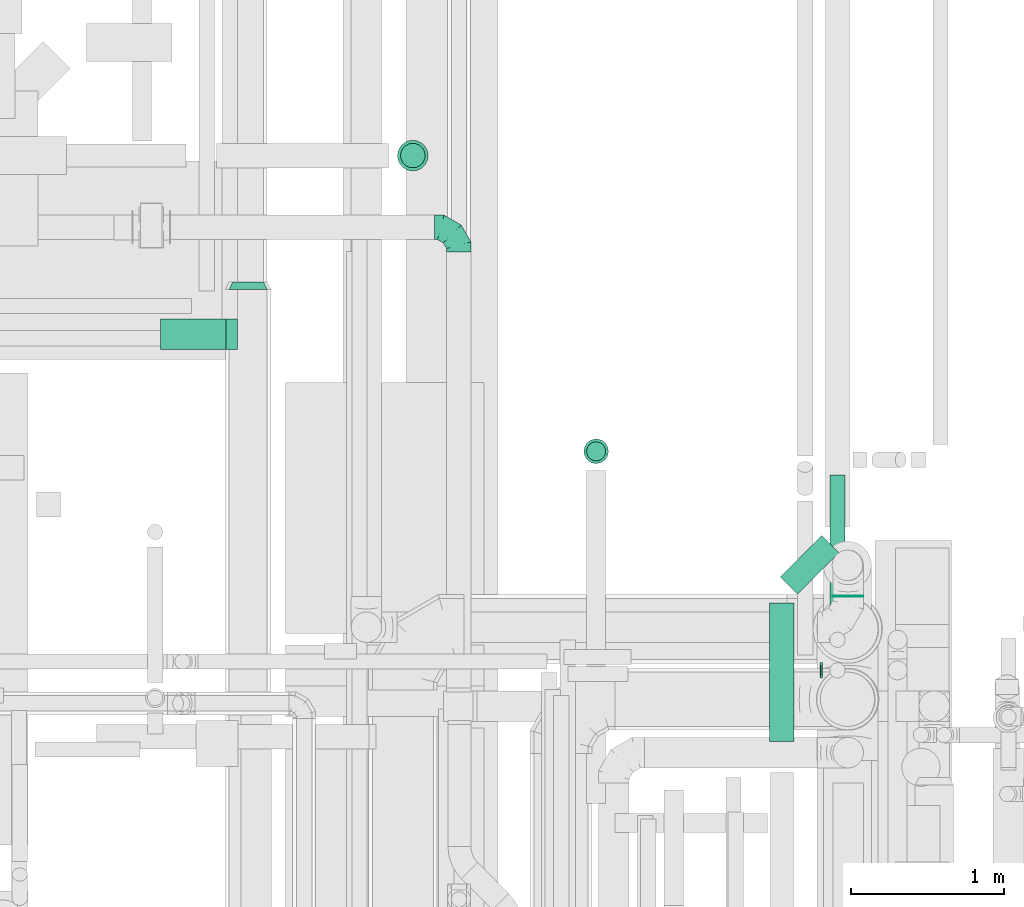
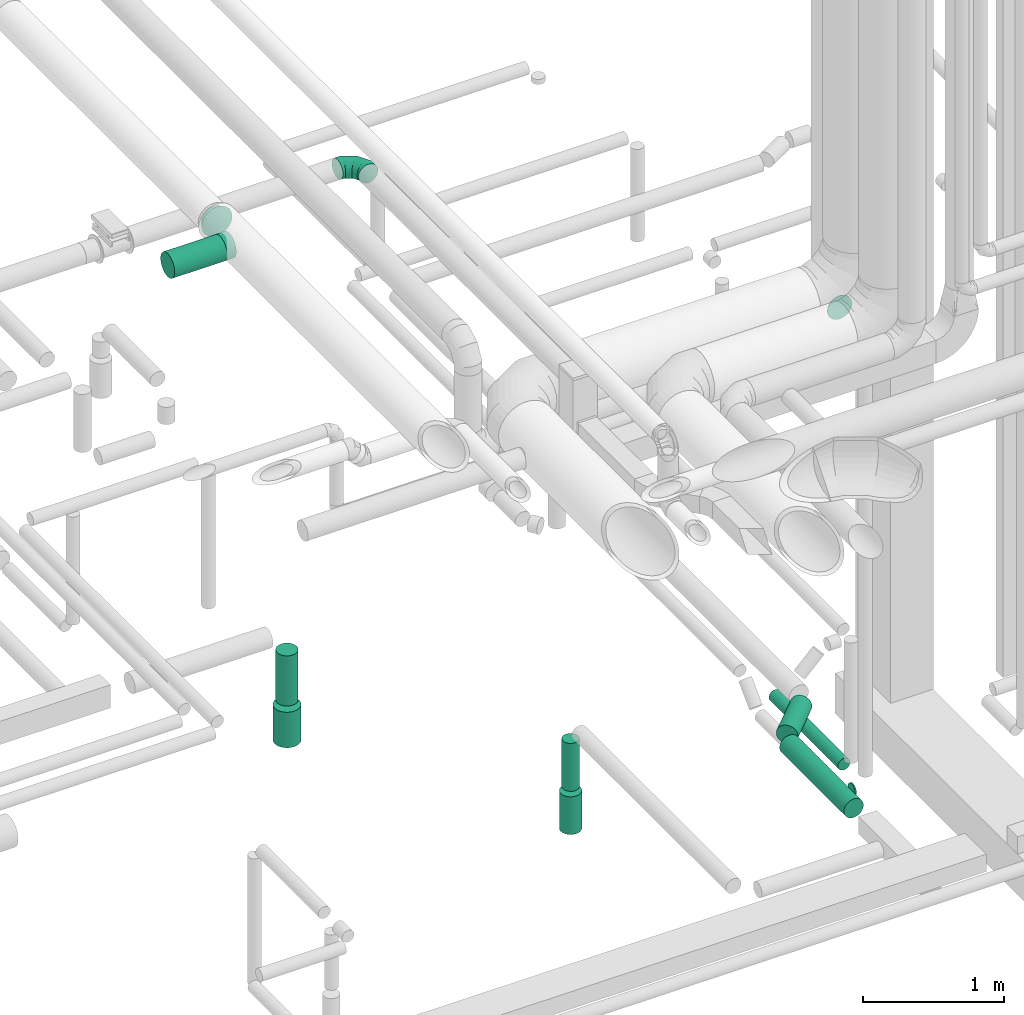
# One storey, part 269 of 337: 10 flow segments, 3 flow fittings.
"""IFC2X3 building model written with IfcOpenShell, lengths in millimetres."""

from ifc_helpers import new_model, entity, si_unit, converted_unit, derived_unit, direction, frame, origin, origin_2d_with_axis, place, context, subcontext, project, spatial, circle, extrude, faceted_brep, source, transform, mapped, material, type_object, type_shapes, element, save


model = new_model("IFC2X3")

# Units and contexts
model_context = context("Model", 3, precision=0.01, world=origin(), true_north=direction((6.12303176911189e-17, 1.0)))
body_context = subcontext(model_context, "Body", "Model", "MODEL_VIEW")
ifc_project = project(units=[si_unit("LENGTHUNIT", "METRE", prefix="MILLI"), si_unit("AREAUNIT", "SQUARE_METRE"), si_unit("VOLUMEUNIT", "CUBIC_METRE"), converted_unit("PLANEANGLEUNIT", "DEGREE", entity("IfcRatioMeasure", 0.0174532925199433), si_unit("PLANEANGLEUNIT", "RADIAN"), dimensions=[0, 0, 0, 0, 0, 0, 0]), si_unit("MASSUNIT", "GRAM", prefix="KILO"), derived_unit("MASSDENSITYUNIT", [(si_unit("MASSUNIT", "GRAM", prefix="KILO"), 1), (si_unit("LENGTHUNIT", "METRE"), -3)]), derived_unit("MOMENTOFINERTIAUNIT", [(si_unit("LENGTHUNIT", "METRE"), 4)]), si_unit("TIMEUNIT", "SECOND"), si_unit("FREQUENCYUNIT", "HERTZ"), si_unit("THERMODYNAMICTEMPERATUREUNIT", "DEGREE_CELSIUS"), derived_unit("THERMALTRANSMITTANCEUNIT", [(si_unit("MASSUNIT", "GRAM", prefix="KILO"), 1), (si_unit("THERMODYNAMICTEMPERATUREUNIT", "KELVIN"), -1), (si_unit("TIMEUNIT", "SECOND"), -3)]), derived_unit("VOLUMETRICFLOWRATEUNIT", [(si_unit("LENGTHUNIT", "METRE"), 3), (si_unit("TIMEUNIT", "SECOND"), -1)]), derived_unit("MASSFLOWRATEUNIT", [(si_unit("MASSUNIT", "GRAM", prefix="KILO"), 1), (si_unit("TIMEUNIT", "SECOND"), -1)]), derived_unit("ROTATIONALFREQUENCYUNIT", [(si_unit("TIMEUNIT", "SECOND"), -1)]), si_unit("ELECTRICCURRENTUNIT", "AMPERE"), si_unit("ELECTRICVOLTAGEUNIT", "VOLT"), si_unit("POWERUNIT", "WATT"), si_unit("FORCEUNIT", "NEWTON", prefix="KILO"), si_unit("ILLUMINANCEUNIT", "LUX"), si_unit("LUMINOUSFLUXUNIT", "LUMEN"), si_unit("LUMINOUSINTENSITYUNIT", "CANDELA"), derived_unit("USERDEFINED", [(si_unit("MASSUNIT", "GRAM", prefix="KILO"), -1), (si_unit("LENGTHUNIT", "METRE"), -2), (si_unit("TIMEUNIT", "SECOND"), 3), (si_unit("LUMINOUSFLUXUNIT", "LUMEN"), 1)]), derived_unit("LINEARVELOCITYUNIT", [(si_unit("LENGTHUNIT", "METRE"), 1), (si_unit("TIMEUNIT", "SECOND"), -1)]), si_unit("PRESSUREUNIT", "PASCAL"), derived_unit("USERDEFINED", [(si_unit("LENGTHUNIT", "METRE"), -2), (si_unit("MASSUNIT", "GRAM", prefix="KILO"), 1), (si_unit("TIMEUNIT", "SECOND"), -2)]), derived_unit("LINEARFORCEUNIT", [(si_unit("MASSUNIT", "GRAM", prefix="KILO"), 1), (si_unit("LENGTHUNIT", "METRE"), 1), (si_unit("TIMEUNIT", "SECOND"), -2), (si_unit("LENGTHUNIT", "METRE"), -1)]), derived_unit("PLANARFORCEUNIT", [(si_unit("MASSUNIT", "GRAM", prefix="KILO"), 1), (si_unit("LENGTHUNIT", "METRE"), 1), (si_unit("TIMEUNIT", "SECOND"), -2), (si_unit("LENGTHUNIT", "METRE"), -2)])], contexts=[model_context])

# Site, building, storey
site_placement = place(None, origin())
site = spatial("IfcSite", under=ifc_project, at=site_placement, CompositionType="ELEMENT")
building_placement = place(site_placement, origin())
building = spatial("IfcBuilding", under=site, at=building_placement, CompositionType="ELEMENT")
storey_placement = place(building_placement, origin())
storey = spatial("IfcBuildingStorey", under=building, at=storey_placement, CompositionType="ELEMENT", Elevation=0.0)

# Flow segments
duct_segment_type = type_object("IfcDuctSegmentType", PredefinedType="NOTDEFINED")
flow_segment_1_placement = place(storey_placement, frame((64612.09, 15247.36, -1790.0)))
element("IfcFlowSegment", 1, at=flow_segment_1_placement, inside=storey, type_object=duct_segment_type, context=body_context, shape_type="SweptSolid", body=[
    extrude(circle(Radius=100.0, at=origin_2d_with_axis()), frame((101.6, 101.6, 0.0), z_axis=(0.0, 0.0, 1.0), x_axis=(-1.0, 0.0, 0.0)), (0.0, 0.0, 1.0), 306.987439478267),
])
flow_segment_2_placement = place(storey_placement, frame((64632.09, 15267.36, -1443.01)))
element("IfcFlowSegment", 2, at=flow_segment_2_placement, inside=storey, type_object=duct_segment_type, context=body_context, shape_type="SweptSolid", body=[
    extrude(circle(Radius=80.0, at=origin_2d_with_axis()), frame((81.6, 81.6, 0.0)), (0.0, 0.0, 1.0), 433.012560521771),
])
flow_segment_3_placement = place(storey_placement, frame((67048.13, 11511.06, -981.6)))
element("IfcFlowSegment", 3, at=flow_segment_3_placement, inside=storey, type_object=duct_segment_type, context=body_context, shape_type="SweptSolid", body=[
    extrude(circle(Radius=80.0, at=origin_2d_with_axis()), frame((81.6, 0.0, 81.6), z_axis=(0.0, 1.0, 0.0), x_axis=(1.0, 0.0, 0.0)), (0.0, 0.0, 1.0), 909.725830020307),
])
flow_segment_4_placement = place(storey_placement, frame((67118.42, 12475.76, -981.6)))
element("IfcFlowSegment", 4, at=flow_segment_4_placement, inside=storey, type_object=duct_segment_type, context=body_context, shape_type="SweptSolid", body=[
    extrude(circle(Radius=80.0, at=origin_2d_with_axis()), frame((58.16, 58.16, 81.6), z_axis=(0.707106781186562, 0.707106781186533, 0.0), x_axis=(0.707106781186533, -0.707106781186562, 0.0)), (0.0, 0.0, 1.0), 382.900697862583),
])
flow_segment_5_placement = place(storey_placement, frame((65832.34, 13331.21, -1799.89)))
element("IfcFlowSegment", 5, at=flow_segment_5_placement, inside=storey, type_object=duct_segment_type, context=body_context, shape_type="SweptSolid", body=[
    extrude(circle(Radius=80.0, at=origin_2d_with_axis()), frame((81.6, 81.6, 0.0)), (0.0, 0.0, 1.0), 326.124652279636),
])
flow_segment_6_placement = place(storey_placement, frame((65849.84, 13348.71, -1438.77)))
element("IfcFlowSegment", 6, at=flow_segment_6_placement, inside=storey, type_object=duct_segment_type, context=body_context, shape_type="SweptSolid", body=[
    extrude(circle(Radius=62.5, at=origin_2d_with_axis()), frame((64.1, 64.1, 0.0)), (0.0, 0.0, 1.0), 413.765350053107),
])
flow_segment_7_placement = place(storey_placement, frame((67382.28, 11926.94, -1161.6)))
element("IfcFlowSegment", 7, at=flow_segment_7_placement, inside=storey, type_object=duct_segment_type, context=body_context, shape_type="SweptSolid", body=[
    extrude(circle(Radius=50.0, at=origin_2d_with_axis()), frame((0.0, 51.6, 51.6), z_axis=(1.0, 0.0, 0.0), x_axis=(0.0, 1.0, 0.0)), (0.0, 0.0, 1.0), 11.9771299999936),
])
flow_segment_8_placement = place(storey_placement, frame((67442.66, 12278.74, -1163.94)))
element("IfcFlowSegment", 8, at=flow_segment_8_placement, inside=storey, type_object=duct_segment_type, context=body_context, shape_type="SweptSolid", body=[
    extrude(circle(Radius=50.0, at=origin_2d_with_axis()), frame((51.6, 0.0, 51.6), z_axis=(0.0, 1.0, 0.0), x_axis=(1.0, 0.0, 0.0)), (0.0, 0.0, 1.0), 977.965679999999),
])
flow_segment_9_placement = place(storey_placement, frame((67462.38, 12460.8, 2598.4)))
element("IfcFlowSegment", 9, at=flow_segment_9_placement, inside=storey, type_object=duct_segment_type, context=body_context, shape_type="SweptSolid", body=[
    extrude(circle(Radius=100.0, at=origin_2d_with_axis()), frame((101.6, 0.0, 101.6), z_axis=(0.0, 1.0, 0.0), x_axis=(1.0, 0.0, 0.0)), (0.0, 0.0, 1.0), 4.99999999998587),
])
flow_segment_10_placement = place(storey_placement, frame((63062.15, 14076.34, 3498.4)))
element("IfcFlowSegment", 10, at=flow_segment_10_placement, inside=storey, type_object=duct_segment_type, context=body_context, shape_type="SweptSolid", body=[
    extrude(circle(Radius=100.0, at=origin_2d_with_axis()), frame((0.0, 101.6, 101.6), z_axis=(1.0, 0.0, 0.0), x_axis=(0.0, 1.0, 0.0)), (0.0, 0.0, 1.0), 428.296653645232),
])

# Flow fittings
ifc_material = material()
duct_fitting_type_1 = type_object("IfcDuctFittingType", PredefinedType="NOTDEFINED", material=ifc_material)
shared_shape_1 = source(origin(), body_context, "Body", "Brep", [
    faceted_brep([(-160.0, 0.0, -80.0), (-160.0, -20.71, -77.27), (-160.0, -40.0, -69.28), (-160.0, -56.57, -56.57), (-160.0, -69.28, -40.0), (-160.0, -77.27, -20.71), (-160.0, -80.0, 0.0), (-160.0, -77.27, 20.71), (-160.0, -69.28, 40.0), (-160.0, -56.57, 56.57), (-160.0, -40.0, 69.28), (-160.0, -20.71, 77.27), (-160.0, 0.0, 80.0), (-160.0, 20.71, 77.27), (-160.0, 40.0, 69.28), (-160.0, 56.57, 56.57), (-160.0, 69.28, 40.0), (-160.0, 77.27, 20.71), (-160.0, 80.0, 0.0), (-160.0, 77.27, -20.71), (-160.0, 69.28, -40.0), (-160.0, 56.57, -56.57), (-160.0, 40.0, -69.28), (-160.0, 20.71, -77.27), (-122.68, 20.71, 77.27), (-127.85, 40.0, 69.28), (-117.13, 0.0, 80.0), (-132.29, 56.57, 56.57), (-137.83, 77.27, 20.71), (-138.56, 80.0, 0.0), (-135.69, 69.28, 40.0), (-135.69, 69.28, -40.0), (-132.29, 56.57, -56.57), (-137.83, 77.27, -20.71), (-122.68, 20.71, -77.27), (-117.13, 0.0, -80.0), (-127.85, 40.0, -69.28), (-111.58, -20.71, -77.27), (-106.41, -40.0, -69.28), (-101.97, -56.57, -56.57), (-98.56, -69.28, -40.0), (-96.42, -77.27, -20.71), (-95.69, -80.0, 0.0), (-96.42, -77.27, 20.71), (-98.56, -69.28, 40.0), (-101.97, -56.57, 56.57), (-106.41, -40.0, 69.28), (-111.58, -20.71, 77.27), (-58.03, 58.03, 77.27), (-72.15, 72.15, 69.28), (-42.87, 42.87, 80.0), (-84.28, 84.28, 56.57), (-93.59, 93.59, 40.0), (-99.44, 99.44, 20.71), (-101.44, 101.44, 0.0), (-99.44, 99.44, -20.71), (-93.59, 93.59, -40.0), (-84.28, 84.28, -56.57), (-58.03, 58.03, -77.27), (-42.87, 42.87, -80.0), (-72.15, 72.15, -69.28), (-27.71, 27.71, -77.27), (-13.59, 13.59, -69.28), (-1.46, 1.46, -56.57), (7.85, -7.85, -40.0), (13.7, -13.7, -20.71), (15.69, -15.69, 0.0), (13.7, -13.7, 20.71), (7.85, -7.85, 40.0), (-1.46, 1.46, 56.57), (-13.59, 13.59, 69.28), (-27.71, 27.71, 77.27), (-20.71, 122.68, 77.27), (-40.0, 127.85, 69.28), (0.0, 117.13, 80.0), (-56.57, 132.29, 56.57), (-69.28, 135.69, 40.0), (-77.27, 137.83, 20.71), (-80.0, 138.56, 0.0), (-77.27, 137.83, -20.71), (-69.28, 135.69, -40.0), (-56.57, 132.29, -56.57), (-20.71, 122.68, -77.27), (0.0, 117.13, -80.0), (-40.0, 127.85, -69.28), (20.71, 111.58, -77.27), (40.0, 106.41, -69.28), (56.57, 101.97, -56.57), (69.28, 98.56, -40.0), (77.27, 96.42, -20.71), (80.0, 95.69, 0.0), (77.27, 96.42, 20.71), (69.28, 98.56, 40.0), (56.57, 101.97, 56.57), (40.0, 106.41, 69.28), (20.71, 111.58, 77.27), (-20.71, 160.0, -77.27), (-40.0, 160.0, -69.28), (-56.57, 160.0, -56.57), (-69.28, 160.0, -40.0), (-77.27, 160.0, -20.71), (-80.0, 160.0, 0.0), (-77.27, 160.0, 20.71), (-69.28, 160.0, 40.0), (-56.57, 160.0, 56.57), (-40.0, 160.0, 69.28), (-20.71, 160.0, 77.27), (0.0, 160.0, 80.0), (20.71, 160.0, 77.27), (40.0, 160.0, 69.28), (56.57, 160.0, 56.57), (69.28, 160.0, 40.0), (77.27, 160.0, 20.71), (80.0, 160.0, 0.0), (77.27, 160.0, -20.71), (69.28, 160.0, -40.0), (56.57, 160.0, -56.57), (40.0, 160.0, -69.28), (20.71, 160.0, -77.27), (0.0, 160.0, -80.0)], [[[0, 1, 2, 3, 4, 5, 6, 7, 8, 9, 10, 11, 12, 13, 14, 15, 16, 17, 18, 19, 20, 21, 22, 23]], [[24, 25, 14, 13]], [[26, 24, 13, 12]], [[14, 25, 27, 15]], [[28, 29, 18, 17]], [[30, 28, 17, 16]], [[15, 27, 30, 16]], [[20, 31, 32, 21]], [[33, 31, 20, 19]], [[18, 29, 33, 19]], [[34, 35, 0, 23]], [[36, 34, 23, 22]], [[32, 36, 22, 21]], [[1, 0, 35, 37]], [[2, 1, 37, 38]], [[3, 2, 38, 39]], [[5, 4, 40, 41]], [[6, 5, 41, 42]], [[39, 40, 4, 3]], [[6, 42, 43, 7]], [[7, 43, 44, 8]], [[8, 44, 45, 9]], [[9, 45, 46, 10]], [[10, 46, 47, 11]], [[26, 12, 11, 47]], [[48, 49, 25, 24]], [[50, 48, 24, 26]], [[27, 25, 49, 51]], [[52, 53, 28, 30]], [[51, 52, 30, 27]], [[29, 28, 53, 54]], [[55, 56, 31, 33]], [[54, 55, 33, 29]], [[32, 31, 56, 57]], [[58, 59, 35, 34]], [[60, 58, 34, 36]], [[57, 60, 36, 32]], [[37, 35, 59, 61]], [[38, 37, 61, 62]], [[39, 38, 62, 63]], [[41, 40, 64, 65]], [[42, 41, 65, 66]], [[63, 64, 40, 39]], [[43, 42, 66, 67]], [[44, 43, 67, 68]], [[68, 69, 45, 44]], [[46, 45, 69, 70]], [[47, 46, 70, 71]], [[26, 47, 71, 50]], [[72, 73, 49, 48]], [[74, 72, 48, 50]], [[51, 49, 73, 75]], [[76, 77, 53, 52]], [[75, 76, 52, 51]], [[54, 53, 77, 78]], [[79, 80, 56, 55]], [[78, 79, 55, 54]], [[57, 56, 80, 81]], [[82, 83, 59, 58]], [[84, 82, 58, 60]], [[81, 84, 60, 57]], [[61, 59, 83, 85]], [[62, 61, 85, 86]], [[63, 62, 86, 87]], [[65, 64, 88, 89]], [[66, 65, 89, 90]], [[87, 88, 64, 63]], [[67, 66, 90, 91]], [[68, 67, 91, 92]], [[92, 93, 69, 68]], [[70, 69, 93, 94]], [[71, 70, 94, 95]], [[50, 71, 95, 74]], [[96, 97, 98, 99, 100, 101, 102, 103, 104, 105, 106, 107, 108, 109, 110, 111, 112, 113, 114, 115, 116, 117, 118, 119]], [[72, 74, 107, 106]], [[73, 72, 106, 105]], [[75, 73, 105, 104]], [[77, 76, 103, 102]], [[78, 77, 102, 101]], [[75, 104, 103, 76]], [[78, 101, 100, 79]], [[79, 100, 99, 80]], [[80, 99, 98, 81]], [[84, 97, 96, 82]], [[82, 96, 119, 83]], [[84, 81, 98, 97]], [[118, 117, 86, 85]], [[119, 118, 85, 83]], [[116, 87, 86, 117]], [[88, 115, 114, 89]], [[89, 114, 113, 90]], [[115, 88, 87, 116]], [[112, 111, 92, 91]], [[113, 112, 91, 90]], [[111, 110, 93, 92]], [[95, 94, 109, 108]], [[74, 95, 108, 107]], [[110, 109, 94, 93]]]),
])
type_shapes(duct_fitting_type_1, [shared_shape_1])
flow_fitting_1_placement = place(storey_placement, frame((65014.49, 14878.74, 3380.0), z_axis=(0.0, 0.0, 1.0), x_axis=(0.0, 1.0, 0.0)))
element("IfcFlowFitting", 11, at=flow_fitting_1_placement, inside=storey, type_object=duct_fitting_type_1, material=ifc_material, context=body_context, shape_type="MappedRepresentation", body=[
    mapped(shared_shape_1, transform((0.0, 0.0, 0.0), scale=1.0)),
])
duct_fitting_type_2 = type_object("IfcDuctFittingType", PredefinedType="NOTDEFINED", material=ifc_material)
shared_shape_2 = source(origin(), body_context, "Body", "Brep", [
    faceted_brep([(50.0, -73.47, -101.13), (50.0, -38.63, -118.88), (50.0, 0.0, -125.0), (50.0, 38.63, -118.88), (50.0, 73.47, -101.13), (50.0, 101.13, -73.47), (50.0, 118.88, -38.63), (50.0, 125.0, 0.0), (50.0, 118.88, 38.63), (50.0, 101.13, 73.47), (50.0, 73.47, 101.13), (50.0, 38.63, 118.88), (50.0, 0.0, 125.0), (50.0, -38.63, 118.88), (50.0, -73.47, 101.13), (50.0, -101.13, 73.47), (50.0, -118.88, 38.63), (50.0, -125.0, 0.0), (50.0, -118.88, -38.63), (50.0, -101.13, -73.47), (0.0, 30.9, -95.11), (0.0, 0.0, -100.0), (0.0, -30.9, -95.11), (0.0, -58.78, -80.9), (0.0, -80.9, -58.78), (0.0, -95.11, -30.9), (0.0, -100.0, 0.0), (0.0, -95.11, 30.9), (0.0, -80.9, 58.78), (0.0, -58.78, 80.9), (0.0, -30.9, 95.11), (0.0, 0.0, 100.0), (0.0, 30.9, 95.11), (0.0, 58.78, 80.9), (0.0, 80.9, 58.78), (0.0, 95.11, 30.9), (0.0, 100.0, 0.0), (0.0, 95.11, -30.9), (0.0, 80.9, -58.78), (0.0, 58.78, -80.9)], [[[0, 1, 2, 3, 4, 5, 6, 7, 8, 9, 10, 11, 12, 13, 14, 15, 16, 17, 18, 19]], [[20, 21, 22, 23, 24, 25, 26, 27, 28, 29, 30, 31, 32, 33, 34, 35, 36, 37, 38, 39]], [[35, 34, 9, 8]], [[36, 35, 8, 7]], [[34, 33, 10, 9]], [[10, 33, 32, 11]], [[11, 32, 31, 12]], [[30, 29, 14, 13]], [[31, 30, 13, 12]], [[29, 28, 15, 14]], [[15, 28, 27, 16]], [[16, 27, 26, 17]], [[25, 24, 19, 18]], [[26, 25, 18, 17]], [[24, 23, 0, 19]], [[0, 23, 22, 1]], [[1, 22, 21, 2]], [[20, 39, 4, 3]], [[21, 20, 3, 2]], [[39, 38, 5, 4]], [[5, 38, 37, 6]], [[6, 37, 36, 7]]]),
])
type_shapes(duct_fitting_type_2, [shared_shape_2])
flow_fitting_2_placement = place(storey_placement, frame((63635.44, 14522.7, 3600.0), z_axis=(-1.0, 0.0, 0.0), x_axis=(0.0, -1.0, 0.0)))
element("IfcFlowFitting", 12, at=flow_fitting_2_placement, inside=storey, type_object=duct_fitting_type_2, material=ifc_material, context=body_context, shape_type="MappedRepresentation", body=[
    mapped(shared_shape_2, transform((0.0, 0.0, 0.0), scale=1.0)),
])
duct_fitting_type_3 = type_object("IfcDuctFittingType", PredefinedType="NOTDEFINED", material=ifc_material)
shared_shape_3 = source(origin(), body_context, "Body", "Brep", [
    faceted_brep([(20.0, 25.88, -96.59), (20.0, 50.0, -86.6), (20.0, 70.71, -70.71), (20.0, 86.6, -50.0), (20.0, 96.59, -25.88), (20.0, 100.0, 0.0), (20.0, 96.59, 25.88), (20.0, 86.6, 50.0), (20.0, 70.71, 70.71), (20.0, 50.0, 86.6), (20.0, 25.88, 96.59), (20.0, 0.0, 100.0), (20.0, -25.88, 96.59), (20.0, -50.0, 86.6), (20.0, -70.71, 70.71), (20.0, -86.6, 50.0), (20.0, -96.59, 25.88), (20.0, -100.0, 0.0), (20.0, -96.59, -25.88), (20.0, -86.6, -50.0), (20.0, -70.71, -70.71), (20.0, -50.0, -86.6), (20.0, -25.88, -96.59), (20.0, 0.0, -100.0), (0.0, 0.0, 100.0), (0.0, 25.88, 96.59), (-56.1, 25.88, 96.59), (-56.1, 0.0, 100.0), (0.0, 50.0, 86.6), (-56.1, 50.0, 86.6), (0.0, 70.71, 70.71), (-56.1, 70.71, 70.71), (0.0, 86.6, 50.0), (0.0, 96.59, 25.88), (-56.1, 96.59, 25.88), (-56.1, 86.6, 50.0), (0.0, 100.0, 0.0), (-56.1, 100.0, 0.0), (0.0, 96.59, -25.88), (-56.1, 96.59, -25.88), (0.0, 86.6, -50.0), (-56.1, 86.6, -50.0), (0.0, 70.71, -70.71), (-56.1, 70.71, -70.71), (0.0, 50.0, -86.6), (0.0, 25.88, -96.59), (-56.1, 25.88, -96.59), (-56.1, 50.0, -86.6), (0.0, 0.0, -100.0), (-56.1, 0.0, -100.0), (0.0, -25.88, -96.59), (-56.1, -25.88, -96.59), (0.0, -50.0, -86.6), (-56.1, -50.0, -86.6), (0.0, -70.71, -70.71), (-56.1, -70.71, -70.71), (0.0, -86.6, -50.0), (0.0, -96.59, -25.88), (-56.1, -96.59, -25.88), (-56.1, -86.6, -50.0), (0.0, -100.0, 0.0), (-56.1, -100.0, 0.0), (0.0, -96.59, 25.88), (-56.1, -96.59, 25.88), (0.0, -86.6, 50.0), (-56.1, -86.6, 50.0), (0.0, -70.71, 70.71), (-56.1, -70.71, 70.71), (0.0, -50.0, 86.6), (0.0, -25.88, 96.59), (-56.1, -25.88, 96.59), (-56.1, -50.0, 86.6)], [[[0, 1, 2, 3, 4, 5, 6, 7, 8, 9, 10, 11, 12, 13, 14, 15, 16, 17, 18, 19, 20, 21, 22, 23]], [[24, 11, 10, 25, 26, 27]], [[25, 10, 9, 28, 29, 26]], [[28, 9, 8, 30, 31, 29]], [[32, 7, 6, 33, 34, 35]], [[33, 6, 5, 36, 37, 34]], [[30, 8, 7, 32, 35, 31]], [[36, 5, 4, 38, 39, 37]], [[38, 4, 3, 40, 41, 39]], [[40, 3, 2, 42, 43, 41]], [[44, 1, 0, 45, 46, 47]], [[45, 0, 23, 48, 49, 46]], [[42, 2, 1, 44, 47, 43]], [[48, 23, 22, 50, 51, 49]], [[50, 22, 21, 52, 53, 51]], [[52, 21, 20, 54, 55, 53]], [[56, 19, 18, 57, 58, 59]], [[57, 18, 17, 60, 61, 58]], [[54, 20, 19, 56, 59, 55]], [[60, 17, 16, 62, 63, 61]], [[62, 16, 15, 64, 65, 63]], [[64, 15, 14, 66, 67, 65]], [[68, 13, 12, 69, 70, 71]], [[69, 12, 11, 24, 27, 70]], [[66, 14, 13, 68, 71, 67]], [[49, 51, 53, 55, 59, 58, 61, 63, 65, 67, 71, 70, 27, 26, 29, 31, 35, 34, 37, 39, 41, 43, 47, 46]]]),
])
type_shapes(duct_fitting_type_3, [shared_shape_3])
flow_fitting_3_placement = place(storey_placement, frame((63510.44, 14177.94, 3600.0), z_axis=(0.0, 0.0, -1.0), x_axis=(-1.0, 0.0, 0.0)))
element("IfcFlowFitting", 13, at=flow_fitting_3_placement, inside=storey, type_object=duct_fitting_type_3, material=ifc_material, context=body_context, shape_type="MappedRepresentation", body=[
    mapped(shared_shape_3, transform((0.0, 0.0, 0.0), scale=1.0)),
])

save(model, "model.ifc")
